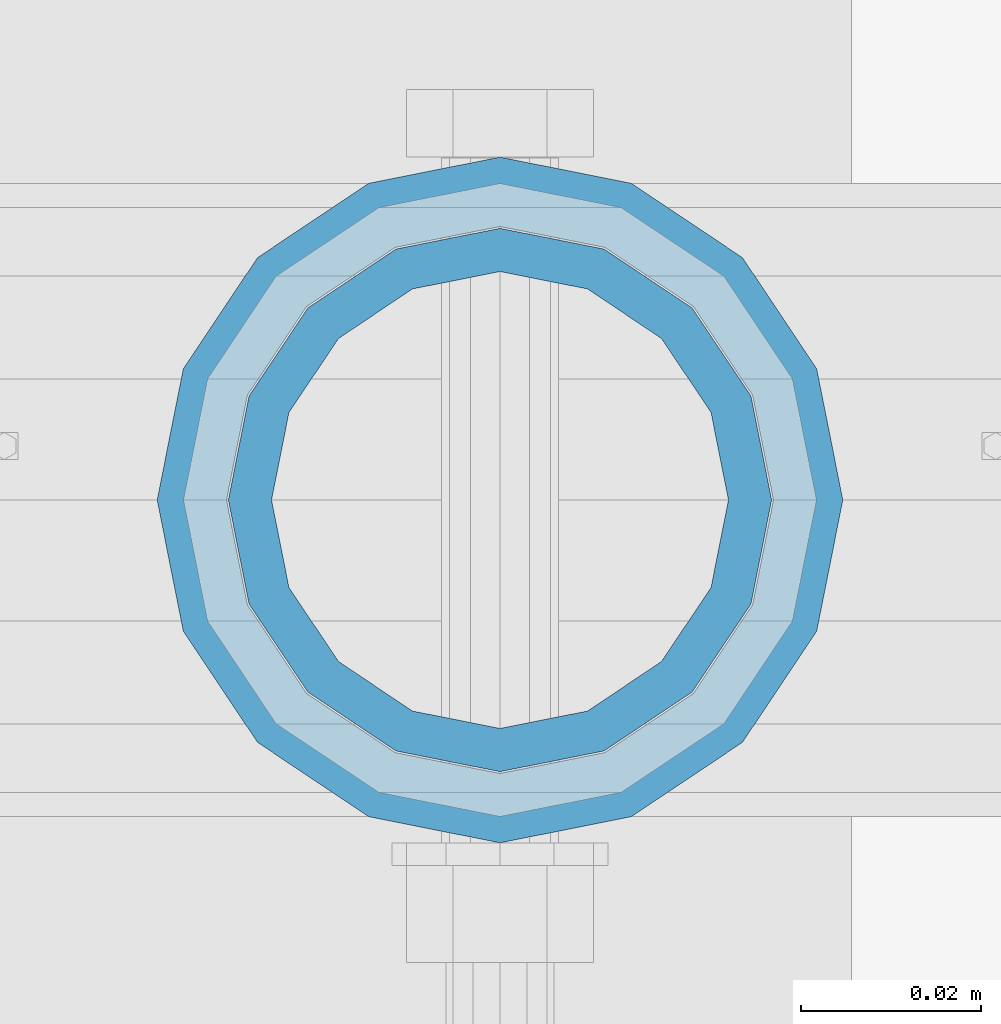
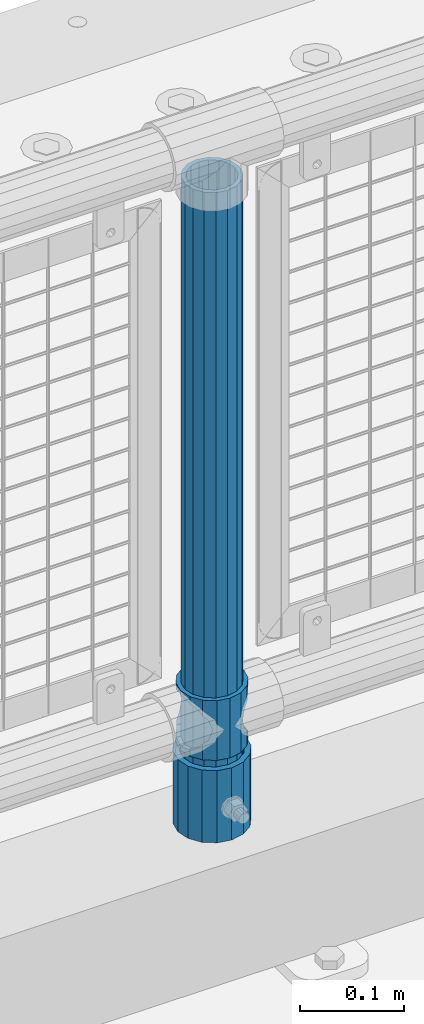
# One storey, part 85 of 257: 3 columns.
"""IFC2X3 building model written with IfcOpenShell, lengths in millimetres."""

from ifc_helpers import new_model, si_unit, frame, origin_with_axes, place, context, subcontext, project, spatial, faceted_brep, material, type_object, element, save


model = new_model("IFC2X3")

# Units and contexts
model_context = context("Model", 3, precision=1e-05, world=origin_with_axes())
body_context = subcontext(model_context, "Body", "Model", "MODEL_VIEW")
ifc_project = project(units=[si_unit("LENGTHUNIT", "METRE", prefix="MILLI"), si_unit("AREAUNIT", "SQUARE_METRE"), si_unit("VOLUMEUNIT", "CUBIC_METRE"), si_unit("MASSUNIT", "GRAM", prefix="KILO"), si_unit("TIMEUNIT", "SECOND"), si_unit("PLANEANGLEUNIT", "RADIAN"), si_unit("SOLIDANGLEUNIT", "STERADIAN"), si_unit("THERMODYNAMICTEMPERATUREUNIT", "DEGREE_CELSIUS"), si_unit("LUMINOUSINTENSITYUNIT", "LUMEN")], contexts=[model_context])

# Site, building, storey
site_placement = place(None, origin_with_axes())
site = spatial("IfcSite", under=ifc_project, at=site_placement, CompositionType="ELEMENT")
building_placement = place(site_placement, origin_with_axes())
building = spatial("IfcBuilding", under=site, at=building_placement, Name="Standard", CompositionType="ELEMENT")
storey_placement = place(building_placement, origin_with_axes())
storey = spatial("IfcBuildingStorey", under=building, at=storey_placement, Name="Undefined", CompositionType="ELEMENT", Elevation=0.0)

# Columns
ifc_material_1 = material()
column_type_1 = type_object("IfcColumnType", PredefinedType="NOTDEFINED")
column_1_placement = place(storey_placement, frame((52671.0, 10664.5, 168.02), z_axis=(0.0, 1.0, 0.0), x_axis=(0.0, 0.0, 1.0)))
element("IfcColumn", 1, at=column_1_placement, inside=storey, type_object=column_type_1, material=ifc_material_1, context=body_context, shape_type="Brep", body=[
    faceted_brep([(0.0, -31.75, 0.0), (0.0, -29.3331751572332, 12.1501989775916), (85.0, -29.3331751572332, 12.1501989775916), (85.0, -31.75, 0.0), (0.0, -22.4506403026753, 22.4506403026735), (85.0, -22.4506403026753, 22.4506403026735), (0.0, -12.1501989775934, 29.3331751572332), (85.0, -12.1501989775934, 29.3331751572332), (0.0, 0.0, 31.75), (85.0, 0.0, 31.75), (0.0, 12.1501989775934, 29.3331751572332), (85.0, 12.1501989775934, 29.3331751572332), (0.0, 22.4506403026753, 22.4506403026735), (85.0, 22.4506403026753, 22.4506403026735), (0.0, 29.3331751572332, 12.1501989775916), (85.0, 29.3331751572332, 12.1501989775916), (0.0, 31.75, 0.0), (85.0, 31.75, 0.0), (0.0, 29.3331751572332, -12.1501989775916), (85.0, 29.3331751572332, -12.1501989775916), (0.0, 22.4506403026753, -22.4506403026735), (85.0, 22.4506403026753, -22.4506403026735), (0.0, 12.1501989775934, -29.3331751572332), (85.0, 12.1501989775934, -29.3331751572332), (0.0, 0.0, -31.75), (85.0, 0.0, -31.75), (0.0, -12.1501989775934, -29.3331751572332), (85.0, -12.1501989775934, -29.3331751572332), (0.0, -22.4506403026753, -22.4506403026735), (85.0, -22.4506403026753, -22.4506403026735), (0.0, -29.3331751572332, -12.1501989775916), (85.0, -29.3331751572332, -12.1501989775916), (0.0, -38.0500000000029, 0.0), (0.0, -35.1536162120537, -14.561104601491), (85.0, -35.1536162120537, -14.561104601491), (85.0, -38.0500000000029, 0.0), (0.0, -26.9054130241493, -26.9054130241475), (85.0, -26.9054130241493, -26.9054130241475), (0.0, -14.5611046014892, -35.1536162120537), (85.0, -14.5611046014892, -35.1536162120537), (0.0, 0.0, -38.0499999999993), (85.0, 0.0, -38.0499999999993), (0.0, 14.5611046014892, -35.1536162120537), (85.0, 14.5611046014892, -35.1536162120537), (0.0, 26.9054130241493, -26.9054130241475), (85.0, 26.9054130241493, -26.9054130241475), (0.0, 35.1536162120537, -14.561104601491), (85.0, 35.1536162120537, -14.561104601491), (0.0, 38.0500000000029, 0.0), (85.0, 38.0500000000029, 0.0), (0.0, 35.1536162120537, 14.561104601491), (85.0, 35.1536162120537, 14.561104601491), (0.0, 26.9054130241493, 26.9054130241475), (85.0, 26.9054130241493, 26.9054130241475), (0.0, 14.5611046014892, 35.1536162120537), (85.0, 14.5611046014892, 35.1536162120537), (0.0, 0.0, 38.0499999999993), (85.0, 0.0, 38.0499999999993), (0.0, -14.5611046014892, 35.1536162120537), (85.0, -14.5611046014892, 35.1536162120537), (0.0, -26.9054130241493, 26.9054130241475), (85.0, -26.9054130241493, 26.9054130241475), (0.0, -35.1536162120537, 14.561104601491), (85.0, -35.1536162120537, 14.561104601491)], [[[0, 1, 2, 3]], [[1, 4, 5, 2]], [[4, 6, 7, 5]], [[6, 8, 9, 7]], [[8, 10, 11, 9]], [[10, 12, 13, 11]], [[12, 14, 15, 13]], [[14, 16, 17, 15]], [[16, 18, 19, 17]], [[18, 20, 21, 19]], [[20, 22, 23, 21]], [[22, 24, 25, 23]], [[24, 26, 27, 25]], [[26, 28, 29, 27]], [[28, 30, 31, 29]], [[30, 0, 3, 31]], [[32, 33, 34, 35]], [[33, 36, 37, 34]], [[36, 38, 39, 37]], [[38, 40, 41, 39]], [[40, 42, 43, 41]], [[42, 44, 45, 43]], [[44, 46, 47, 45]], [[46, 48, 49, 47]], [[48, 50, 51, 49]], [[50, 52, 53, 51]], [[52, 54, 55, 53]], [[54, 56, 57, 55]], [[56, 58, 59, 57]], [[58, 60, 61, 59]], [[60, 62, 63, 61]], [[62, 32, 35, 63]], [[37, 39, 41, 43, 45, 47, 49, 51, 53, 55, 57, 59, 61, 63, 35, 34], [5, 7, 9, 11, 13, 15, 17, 19, 21, 23, 25, 27, 29, 31, 3, 2]], [[62, 60, 58, 56, 54, 52, 50, 48, 46, 44, 42, 40, 38, 36, 33, 32], [30, 28, 26, 24, 22, 20, 18, 16, 14, 12, 10, 8, 6, 4, 1, 0]]]),
])
ifc_material_2 = material(Name="Misc_Undefined")
column_type_2 = type_object("IfcColumnType", PredefinedType="NOTDEFINED")
column_2_placement = place(storey_placement, frame((52671.0, 10664.5, 263.02), z_axis=(-1.0, 0.0, 0.0), x_axis=(0.0, 0.0, 1.0)))
element("IfcColumn", 2, at=column_2_placement, inside=storey, type_object=column_type_2, material=ifc_material_2, context=body_context, shape_type="Brep", body=[
    faceted_brep([(63.1897438117172, 11.6144421722802, -32.8397438117245), (63.1897438117172, 11.6144421722802, -28.0397438117143), (56.6106908090114, 21.4606908090118, -21.4606908090136), (56.6106908090114, 21.4606908090118, -27.1226768591077), (61.9623795176756, 13.4513226476338, -32.4743655677739), (46.7644421722801, 28.0397438117179, -11.6144421722784), (46.7644421722801, 28.0397438117179, -20.0882031229921), (51.5310424080039, 24.8548033587067, -24.8548033587067), (35.1500000000015, 30.35, 0.0), (35.1499999999996, 30.3500000000004, -16.6306603983758), (23.5355578277192, 28.0397438117179, -11.6144421722784), (23.5355578277192, 28.0397438117179, -20.0882031229921), (18.7689575919954, 24.8548033587067, -24.8548033587067), (13.6893091909879, 21.4606908090118, -21.4606908090136), (13.6893091909879, 21.4606908090118, -27.1226768591077), (8.3376204823237, 13.4513226476338, -32.4743655677739), (7.11025618828211, 11.6144421722802, -28.0397438117143), (7.11025618828211, 11.6144421722802, -32.8397438117245), (4.79999999999961, 0.0, -30.3499999999985), (4.79999999999961, 0.0, -35.1500000000015), (7.11025618828205, -11.6144421722802, -28.0397438117143), (7.11025618828205, -11.6144421722802, -32.8397438117245), (13.6893091909879, -21.4606908090118, -21.4606908090136), (13.6893091909879, -21.4606908090118, -27.1226768591077), (8.33762048232484, -13.4513226476338, -32.4743655677739), (23.5355578277191, -28.0397438117179, -11.6144421722784), (23.5355578277191, -28.0397438117179, -20.0882031229849), (18.7689575919987, -24.8548033587067, -24.8548033587067), (35.1500000000015, -30.35, 0.0), (35.1499999999996, -30.3500000000004, -16.6306603983685), (46.7644421722801, -28.0397438117179, -11.6144421722784), (46.7644421722801, -28.0397438117179, -20.0882031229849), (51.5310424080038, -24.8548033587067, -24.8548033587067), (56.6106908090114, -21.4606908090118, -21.4606908090136), (56.6106908090114, -21.4606908090118, -27.1226768591077), (61.9623795176756, -13.4513226476338, -32.4743655677739), (63.1897438117172, -11.6144421722802, -28.0397438117143), (63.1897438117172, -11.6144421722802, -32.8397438117245), (65.4999999999997, 0.0, -30.3499999999985), (65.4999999999997, 0.0, -35.1500000000015), (0.0, -28.0397438117179, -11.6144421722784), (0.0, -30.3500000000004, 0.0), (0.0, -21.4606908090118, -21.4606908090136), (0.0, -11.6144421722802, -28.0397438117143), (0.0, 0.0, -30.3499999999985), (0.0, 11.6144421722802, -28.0397438117143), (0.0, 21.4606908090118, -21.4606908090136), (0.0, 28.0397438117179, -11.6144421722784), (0.0, 30.3500000000004, 0.0), (0.0, 28.0397438117179, 11.6144421722784), (23.5355578277192, 28.0397438117179, 11.6144421722784), (0.0, 21.4606908090118, 21.4606908090136), (13.6893091909879, 21.4606908090118, 21.4606908090136), (0.0, 11.6144421722802, 28.0397438117143), (7.11025618828211, 11.6144421722802, 28.0397438117143), (0.0, 0.0, 30.3499999999985), (4.79999999999961, 0.0, 30.3499999999985), (0.0, -11.6144421722802, 28.0397438117143), (7.11025618828205, -11.6144421722802, 28.0397438117143), (0.0, -21.4606908090118, 21.4606908090136), (13.6893091909879, -21.4606908090118, 21.4606908090136), (0.0, -28.0397438117179, 11.6144421722784), (23.5355578277191, -28.0397438117179, 11.6144421722784), (0.0, -32.4743655677721, 13.4513226476338), (0.0, -35.1499999999996, 0.0), (70.2999999999993, -35.1499999999996, 0.0), (70.2999999999993, -32.4743655677721, 13.4513226476338), (0.0, 13.4513226476338, -32.4743655677739), (0.0, 24.8548033587067, -24.8548033587067), (0.0, 0.0, -35.1499999999996), (0.0, -13.4513226476338, -32.4743655677739), (0.0, -24.8548033587067, -24.8548033587067), (0.0, -24.8548033587067, 24.8548033587067), (0.0, -13.4513226476338, 32.4743655677739), (0.0, 0.0, 35.1499999999996), (0.0, 13.4513226476338, 32.4743655677739), (0.0, 24.8548033587067, 24.8548033587067), (0.0, 32.4743655677721, 13.4513226476338), (0.0, 35.1499999999996, 0.0), (0.0, 32.4743655677721, -13.4513226476338), (0.0, -32.4743655677721, -13.4513226476338), (70.2999999999993, 32.4743655677721, 13.4513226476338), (70.2999999999993, 35.1499999999996, 0.0), (70.2999999999993, 32.4743655677721, -13.4513226476338), (70.2999999999993, 24.8548033587067, -24.8548033587067), (70.2999999999993, 13.4513226476338, -32.4743655677739), (70.2999999999993, 0.0, -35.1500000000015), (70.2999999999993, -13.4513226476338, -32.4743655677739), (70.2999999999993, -24.8548033587067, -24.8548033587067), (70.2999999999993, -32.4743655677721, -13.4513226476338), (70.2999999999993, 28.0397438117179, 11.6144421722784), (70.2999999999993, 21.4606908090118, 21.4606908090136), (56.6106908090114, 21.4606908090118, 21.4606908090136), (46.7644421722801, 28.0397438117179, 11.6144421722784), (70.2999999999993, 11.6144421722802, 28.0397438117143), (63.1897438117172, 11.6144421722802, 28.0397438117143), (70.2999999999993, 0.0, 30.3499999999985), (65.4999999999997, 0.0, 30.3499999999985), (70.2999999999993, -11.6144421722802, 28.0397438117143), (63.1897438117172, -11.6144421722802, 28.0397438117143), (70.2999999999993, -21.4606908090118, 21.4606908090136), (56.6106908090114, -21.4606908090118, 21.4606908090136), (70.2999999999993, -28.0397438117179, 11.6144421722784), (46.7644421722801, -28.0397438117179, 11.6144421722784), (70.2999999999993, -11.6144421722802, -28.0397438117143), (70.2999999999993, 0.0, -30.3499999999985), (70.2999999999993, -21.4606908090118, -21.4606908090136), (70.2999999999993, -28.0397438117179, -11.6144421722784), (70.2999999999993, -30.3500000000004, 0.0), (70.2999999999993, 24.8548033587067, 24.8548033587067), (70.2999999999993, 13.4513226476338, 32.4743655677739), (70.2999999999993, 0.0, 35.1500000000015), (70.2999999999993, -13.4513226476338, 32.4743655677739), (70.2999999999993, -24.8548033587067, 24.8548033587067), (70.2999999999993, 30.3500000000004, 0.0), (70.2999999999993, 28.0397438117179, -11.6144421722784), (70.2999999999993, 21.4606908090118, -21.4606908090136), (70.2999999999993, 11.6144421722802, -28.0397438117143), (61.9623795176756, 13.4513226476338, 32.4743655677739), (51.5310424080039, 24.8548033587067, 24.8548033587067), (56.6106908090114, 21.4606908090118, 27.1226768591077), (65.4999999999997, 0.0, 35.1500000000015), (63.1897438117172, 11.6144421722802, 32.8397438117172), (63.1897438117172, -11.6144421722802, 32.8397438117172), (61.9623795176756, -13.4513226476338, 32.4743655677739), (56.6106908090114, -21.4606908090118, 27.1226768591077), (51.5310424080071, -24.8548033587067, 24.8548033587067), (18.7689575919987, -24.8548033587067, 24.8548033587067), (46.7644421722801, -28.0397438117179, 20.0882031229703), (35.1499999999996, -30.3500000000004, 16.6306603983539), (23.5355578277191, -28.0397438117179, 20.0882031229703), (8.3376204823237, -13.4513226476338, 32.4743655677739), (13.6893091909879, -21.4606908090118, 27.1226768591077), (4.79999999999961, 0.0, 35.1500000000015), (7.11025618828205, -11.6144421722802, 32.8397438117172), (7.11025618828211, 11.6144421722802, 32.8397438117172), (8.3376204823237, 13.4513226476338, 32.4743655677739), (13.6893091909879, 21.4606908090118, 27.1226768591077), (18.7689575919954, 24.8548033587067, 24.8548033587067), (23.5355578277192, 28.0397438117179, 20.0882031229849), (35.1499999999996, 30.3500000000004, 16.6306603983685), (46.7644421722801, 28.0397438117179, 20.0882031229849)], [[[0, 1, 2, 3, 4]], [[3, 2, 5, 6, 7]], [[6, 5, 8, 9]], [[9, 8, 10, 11]], [[12, 11, 10, 13, 14]], [[15, 14, 13, 16, 17]], [[17, 16, 18, 19]], [[19, 18, 20, 21]], [[21, 20, 22, 23, 24]], [[23, 22, 25, 26, 27]], [[26, 25, 28, 29]], [[29, 28, 30, 31]], [[32, 31, 30, 33, 34]], [[35, 34, 33, 36, 37]], [[37, 36, 38, 39]], [[39, 38, 1, 0]], [[40, 41, 28, 25]], [[42, 40, 25, 22]], [[43, 42, 22, 20]], [[44, 43, 20, 18]], [[45, 44, 18, 16]], [[46, 45, 16, 13]], [[47, 46, 13, 10]], [[48, 47, 10, 8]], [[49, 48, 8, 50]], [[51, 49, 50, 52]], [[53, 51, 52, 54]], [[55, 53, 54, 56]], [[57, 55, 56, 58]], [[59, 57, 58, 60]], [[61, 59, 60, 62]], [[41, 61, 62, 28]], [[63, 64, 65, 66]], [[67, 68, 12, 14, 15]], [[69, 67, 15, 17, 19]], [[24, 70, 69, 19, 21]], [[27, 71, 70, 24, 23]], [[63, 72, 73, 74, 75, 76, 77, 78, 79, 68, 67, 69, 70, 71, 80, 64], [40, 42, 43, 44, 45, 46, 47, 48, 49, 51, 53, 55, 57, 59, 61, 41]], [[78, 77, 81, 82]], [[79, 78, 82, 83]], [[9, 11, 12, 68, 79, 83, 84, 7, 6]], [[7, 84, 85, 4, 3]], [[4, 85, 86, 39, 0]], [[87, 88, 32, 34, 35]], [[86, 87, 35, 37, 39]], [[88, 89, 80, 71, 27, 26, 29, 31, 32]], [[64, 80, 89, 65]], [[90, 91, 92, 93]], [[91, 94, 95, 92]], [[94, 96, 97, 95]], [[96, 98, 99, 97]], [[98, 100, 101, 99]], [[100, 102, 103, 101]], [[104, 105, 38, 36]], [[106, 104, 36, 33]], [[107, 106, 33, 30]], [[108, 107, 30, 28]], [[102, 108, 28, 103]], [[88, 87, 86, 85, 84, 83, 82, 81, 109, 110, 111, 112, 113, 66, 65, 89], [100, 98, 96, 94, 91, 90, 114, 115, 116, 117, 105, 104, 106, 107, 108, 102]], [[118, 110, 109, 119, 120]], [[121, 111, 110, 118, 122]], [[112, 111, 121, 123, 124]], [[113, 112, 124, 125, 126]], [[127, 72, 63, 66, 113, 126, 128, 129, 130]], [[131, 73, 72, 127, 132]], [[133, 74, 73, 131, 134]], [[75, 74, 133, 135, 136]], [[76, 75, 136, 137, 138]], [[119, 109, 81, 77, 76, 138, 139, 140, 141]], [[92, 120, 119, 141, 93]], [[95, 122, 118, 120, 92]], [[97, 121, 122, 95]], [[99, 123, 121, 97]], [[101, 125, 124, 123, 99]], [[103, 128, 126, 125, 101]], [[28, 129, 128, 103]], [[62, 130, 129, 28]], [[60, 132, 127, 130, 62]], [[58, 134, 131, 132, 60]], [[56, 133, 134, 58]], [[54, 135, 133, 56]], [[52, 137, 136, 135, 54]], [[50, 139, 138, 137, 52]], [[8, 140, 139, 50]], [[93, 141, 140, 8]], [[114, 90, 93, 8]], [[115, 114, 8, 5]], [[116, 115, 5, 2]], [[117, 116, 2, 1]], [[105, 117, 1, 38]]]),
])
column_type_3 = type_object("IfcColumnType", PredefinedType="NOTDEFINED")
column_3_placement = place(storey_placement, frame((52671.0, 10664.5, 168.02), z_axis=(-1.0, 0.0, 0.0), x_axis=(0.0, 0.0, 1.0)))
element("IfcColumn", 3, at=column_3_placement, inside=storey, type_object=column_type_3, material=ifc_material_1, context=body_context, shape_type="Brep", body=[
    faceted_brep([(0.0, -25.3500000000004, 0.0), (0.0, -23.4203461491616, 9.70102501045767), (760.0, -23.4203461491616, 9.70102501045767), (760.0, -25.3500000000004, 0.0), (0.0, -17.9251569030785, 17.9251569030821), (760.0, -17.9251569030785, 17.9251569030821), (0.0, -9.70102501045585, 23.4203461491634), (760.0, -9.70102501045585, 23.4203461491634), (0.0, 0.0, 25.3499999999985), (760.0, 0.0, 25.3499999999985), (0.0, 9.70102501045585, 23.4203461491634), (760.0, 9.70102501045585, 23.4203461491634), (0.0, 17.9251569030785, 17.9251569030821), (760.0, 17.9251569030785, 17.9251569030821), (0.0, 23.4203461491616, 9.70102501045767), (760.0, 23.4203461491616, 9.70102501045767), (0.0, 25.3500000000004, 0.0), (760.0, 25.3500000000004, 0.0), (0.0, 23.4203461491616, -9.70102501045767), (760.0, 23.4203461491616, -9.70102501045767), (0.0, 17.9251569030785, -17.9251569030821), (760.0, 17.9251569030785, -17.9251569030821), (0.0, 9.70102501045585, -23.4203461491634), (760.0, 9.70102501045585, -23.4203461491634), (0.0, 0.0, -25.3499999999985), (760.0, 0.0, -25.3499999999985), (0.0, -9.70102501045585, -23.4203461491634), (760.0, -9.70102501045585, -23.4203461491634), (0.0, -17.9251569030785, -17.9251569030821), (760.0, -17.9251569030785, -17.9251569030821), (0.0, -23.4203461491616, -9.70102501045767), (760.0, -23.4203461491616, -9.70102501045767), (0.0, -30.1499999999996, 0.0), (0.0, -27.8549679052157, -11.5379054858058), (760.0, -27.8549679052157, -11.5379054858058), (760.0, -30.1499999999996, 0.0), (0.0, -21.3192694527752, -21.3192694527752), (760.0, -21.3192694527752, -21.3192694527752), (0.0, -11.5379054858076, -27.8549679052157), (760.0, -11.5379054858076, -27.8549679052157), (0.0, 0.0, -30.1500000000015), (760.0, 0.0, -30.1500000000015), (0.0, 11.5379054858076, -27.8549679052157), (760.0, 11.5379054858076, -27.8549679052157), (0.0, 21.3192694527752, -21.3192694527752), (760.0, 21.3192694527752, -21.3192694527752), (0.0, 27.8549679052157, -11.5379054858058), (760.0, 27.8549679052157, -11.5379054858058), (0.0, 30.1499999999996, 0.0), (760.0, 30.1499999999996, 0.0), (0.0, 27.8549679052157, 11.5379054858058), (760.0, 27.8549679052157, 11.5379054858058), (0.0, 21.3192694527752, 21.3192694527752), (760.0, 21.3192694527752, 21.3192694527752), (0.0, 11.5379054858076, 27.8549679052157), (760.0, 11.5379054858076, 27.8549679052157), (0.0, 0.0, 30.1500000000015), (760.0, 0.0, 30.1500000000015), (0.0, -11.5379054858076, 27.8549679052157), (760.0, -11.5379054858076, 27.8549679052157), (0.0, -21.3192694527752, 21.3192694527752), (760.0, -21.3192694527752, 21.3192694527752), (0.0, -27.8549679052157, 11.5379054858058), (760.0, -27.8549679052157, 11.5379054858058)], [[[0, 1, 2, 3]], [[1, 4, 5, 2]], [[4, 6, 7, 5]], [[6, 8, 9, 7]], [[8, 10, 11, 9]], [[10, 12, 13, 11]], [[12, 14, 15, 13]], [[14, 16, 17, 15]], [[16, 18, 19, 17]], [[18, 20, 21, 19]], [[20, 22, 23, 21]], [[22, 24, 25, 23]], [[24, 26, 27, 25]], [[26, 28, 29, 27]], [[28, 30, 31, 29]], [[30, 0, 3, 31]], [[32, 33, 34, 35]], [[33, 36, 37, 34]], [[36, 38, 39, 37]], [[38, 40, 41, 39]], [[40, 42, 43, 41]], [[42, 44, 45, 43]], [[44, 46, 47, 45]], [[46, 48, 49, 47]], [[48, 50, 51, 49]], [[50, 52, 53, 51]], [[52, 54, 55, 53]], [[54, 56, 57, 55]], [[56, 58, 59, 57]], [[58, 60, 61, 59]], [[60, 62, 63, 61]], [[62, 32, 35, 63]], [[37, 39, 41, 43, 45, 47, 49, 51, 53, 55, 57, 59, 61, 63, 35, 34], [5, 7, 9, 11, 13, 15, 17, 19, 21, 23, 25, 27, 29, 31, 3, 2]], [[62, 60, 58, 56, 54, 52, 50, 48, 46, 44, 42, 40, 38, 36, 33, 32], [30, 28, 26, 24, 22, 20, 18, 16, 14, 12, 10, 8, 6, 4, 1, 0]]]),
])

save(model, "model.ifc")
